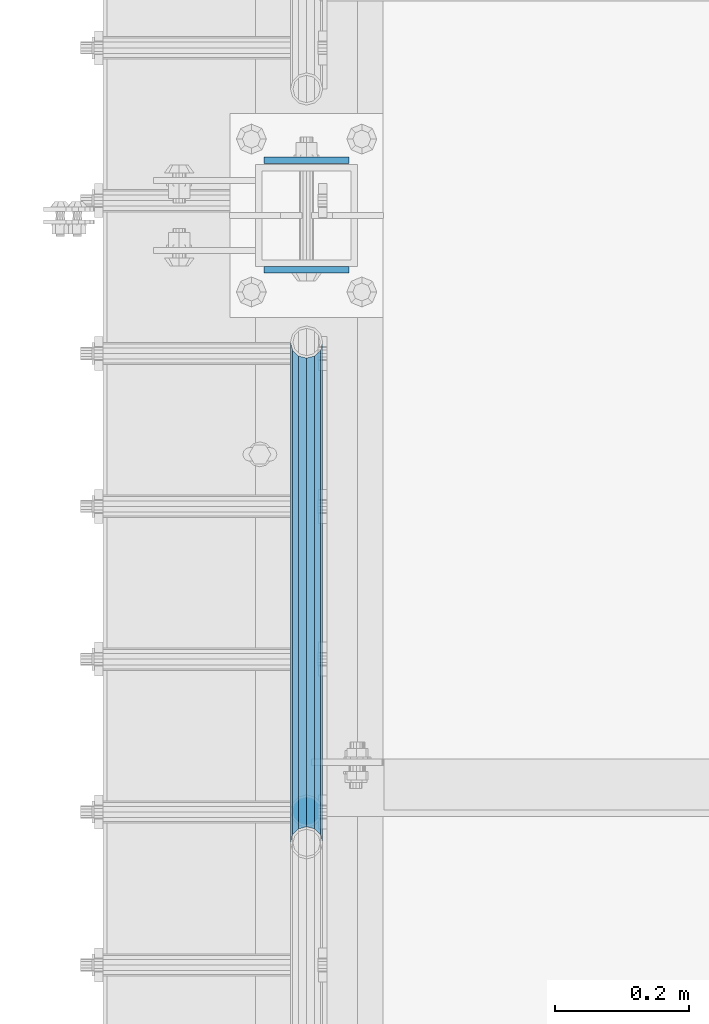
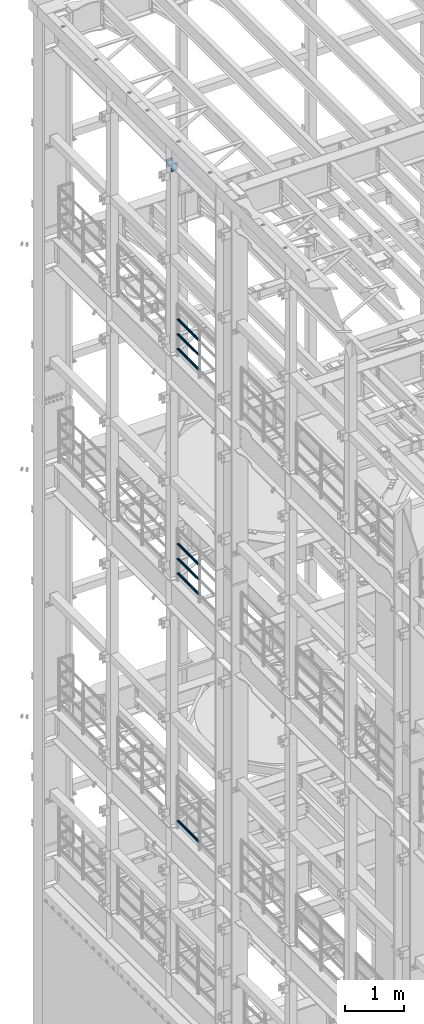
# One storey, part 1295 of 1876: 9 beams, 4 elements without a shape of their own.
"""IFC2X3 building model written with IfcOpenShell, lengths in millimetres."""

from ifc_helpers import new_model, si_unit, frame, origin_with_axes, place, context, subcontext, project, spatial, faceted_brep, material, type_object, element, aggregate, save


model = new_model("IFC2X3")

# Units and contexts
model_context = context("Model", 3, precision=1e-05, world=origin_with_axes())
body_context = subcontext(model_context, "Body", "Model", "MODEL_VIEW")
ifc_project = project(units=[si_unit("LENGTHUNIT", "METRE", prefix="MILLI"), si_unit("AREAUNIT", "SQUARE_METRE"), si_unit("VOLUMEUNIT", "CUBIC_METRE"), si_unit("MASSUNIT", "GRAM", prefix="KILO"), si_unit("TIMEUNIT", "SECOND"), si_unit("PLANEANGLEUNIT", "RADIAN"), si_unit("SOLIDANGLEUNIT", "STERADIAN"), si_unit("THERMODYNAMICTEMPERATUREUNIT", "DEGREE_CELSIUS"), si_unit("LUMINOUSINTENSITYUNIT", "LUMEN")], contexts=[model_context])

# Site, building, storey
site_placement = place(None, origin_with_axes())
site = spatial("IfcSite", under=ifc_project, at=site_placement, CompositionType="ELEMENT")
building_placement = place(site_placement, origin_with_axes())
building = spatial("IfcBuilding", under=site, at=building_placement, Name="Undefined", CompositionType="ELEMENT")
storey_placement = place(building_placement, origin_with_axes())
storey = spatial("IfcBuildingStorey", under=building, at=storey_placement, Name="Undefined", CompositionType="ELEMENT", Elevation=0.0)

# Assembly, beams
assembly_1_placement = place(storey_placement, origin_with_axes())
assembly_1 = element("IfcElementAssembly", 1, at=assembly_1_placement, inside=storey, Name="RAIL", AssemblyPlace="NOTDEFINED", PredefinedType="RIGID_FRAME")
ifc_material_1 = material()
beam_type_1 = type_object("IfcBeamType", Name="PIPE1-1/2SCH40", PredefinedType="NOTDEFINED")
beam_1_placement = place(assembly_1_placement, frame((-1.81898940354586e-12, 9462.77, 18145.125), z_axis=(0.0, 0.0, 1.0), x_axis=(0.0, -1.0, 0.0)))
beam_1 = element("IfcBeam", 2, at=beam_1_placement, type_object=beam_type_1, material=ifc_material_1, Name="RAIL", ObjectType="PIPE1-1/2SCH40", context=body_context, shape_type="Brep", body=[
    faceted_brep([(728.085307006683, -12.0649999999996, 20.8971929933177), (728.085307006683, -12.0649999999996, 15.8661214311796), (727.591878568821, -10.2235000000001, 17.7076214311819), (724.852500000002, 0.0, 20.4470000000001), (724.852500000002, 0.0, 24.130000000001), (727.591878568821, 10.2235000000001, 17.7076214311819), (728.085307006683, 12.0649999999996, 15.8661214311796), (728.085307006683, 12.0649999999996, 20.8971929933177), (748.982500000002, 24.1300000000001, 0.0), (736.917500000002, 20.8971929933186, 12.0649999999987), (736.917500000002, 20.8971929933186, -12.0649999999987), (733.727928437864, 17.7076214311801, 10.2235000000001), (736.467307006683, 20.4470000000001, 0.0), (733.727928437864, 17.7076214311801, -10.2235000000001), (728.085307006683, 12.0649999999996, -15.8661214311796), (728.085307006683, 12.0649999999996, -20.8971929933177), (727.591878568821, 10.2235000000001, -17.7076214311819), (724.852500000002, 0.0, -20.4470000000001), (724.852500000002, 0.0, -24.130000000001), (728.085307006683, -12.0649999999996, -15.8661214311796), (728.085307006683, -12.0649999999996, -20.8971929933177), (727.591878568821, -10.2235000000001, -17.7076214311819), (748.982500000002, -24.1300000000001, 0.0), (736.917500000002, -20.8971929933186, -12.0649999999987), (736.917500000002, -20.8971929933186, 12.0649999999987), (733.727928437864, -17.7076214311801, -10.2235000000001), (736.467307006683, -20.4470000000001, 0.0), (733.727928437864, -17.7076214311801, 10.2235000000001), (12.0650000000064, -20.8971929933177, -12.0649999999987), (20.8971929933249, -12.0650000000005, -20.8971929933177), (0.0, 24.1299999999992, 0.0), (12.0650000000064, 20.8971929933177, -12.0649999999987), (12.0650000000064, 20.8971929933177, 12.0649999999987), (20.8971929933249, 12.0650000000005, 20.8971929933177), (24.1300000000064, 0.0, 24.130000000001), (20.8971929933249, 12.0650000000005, -20.8971929933177), (24.1300000000063, 0.0, -24.130000000001), (24.1300000000063, 0.0, -20.4470000000001), (20.8971929933249, -12.0650000000005, -15.8661214311796), (21.3906214311868, -10.2235000000001, -17.7076214311819), (21.3906214311868, 10.2235000000001, -17.7076214311819), (20.8971929933249, 12.0650000000005, -15.8661214311796), (15.2545715621445, 17.7076214311801, -10.2235000000001), (12.5151929933249, 20.4470000000001, 0.0), (15.2545715621445, 17.7076214311801, 10.2235000000001), (20.8971929933249, 12.0650000000005, 15.8661214311796), (21.3906214311868, 10.2235000000001, 17.7076214311819), (24.1300000000064, 0.0, 20.4470000000001), (21.3906214311868, -10.2235000000001, 17.7076214311819), (20.8971929933249, -12.0650000000005, 15.8661214311796), (20.8971929933249, -12.0650000000005, 20.8971929933177), (12.0650000000064, -20.8971929933177, 12.0649999999987), (0.0, -24.1299999999992, 0.0), (15.2545715621445, -17.7076214311801, 10.2235000000001), (12.5151929933249, -20.4470000000001, 0.0), (15.2545715621445, -17.7076214311801, -10.2235000000001)], [[[0, 1, 2, 3, 4]], [[4, 3, 5, 6, 7]], [[8, 9, 10]], [[7, 6, 11, 12, 13, 14, 15, 10, 9]], [[16, 17, 18, 15, 14]], [[19, 20, 18, 17, 21]], [[22, 23, 24]], [[24, 23, 20, 19, 25, 26, 27, 1, 0]], [[28, 29, 20, 23]], [[30, 31, 32]], [[33, 34, 4, 7]], [[32, 33, 7, 9]], [[30, 32, 9, 8]], [[31, 30, 8, 10]], [[35, 31, 10, 15]], [[36, 35, 15, 18]], [[29, 36, 18, 20]], [[37, 36, 29, 38, 39]], [[40, 41, 35, 36, 37]], [[32, 31, 35, 41, 42, 43, 44, 45, 33]], [[33, 45, 46, 47, 34]], [[34, 47, 48, 49, 50]], [[34, 50, 0, 4]], [[50, 51, 24, 0]], [[51, 52, 22, 24]], [[52, 28, 23, 22]], [[51, 28, 52]], [[50, 49, 53, 54, 55, 38, 29, 28, 51]], [[55, 54, 26, 25]], [[21, 39, 38, 55, 25, 19]], [[37, 39, 21, 17]], [[40, 37, 17, 16]], [[42, 41, 40, 16, 14, 13]], [[43, 42, 13, 12]], [[44, 43, 12, 11]], [[5, 46, 45, 44, 11, 6]], [[47, 46, 5, 3]], [[48, 47, 3, 2]], [[53, 49, 48, 2, 1, 27]], [[54, 53, 27, 26]]]),
])
beam_2_placement = place(assembly_1_placement, frame((-1.81898940354586e-12, 8713.7875, 18449.925), z_axis=(0.0, 0.0, -1.0), x_axis=(0.0, 1.0, 0.0)))
beam_2 = element("IfcBeam", 3, at=beam_2_placement, type_object=beam_type_1, material=ifc_material_1, Name="RAIL", ObjectType="PIPE1-1/2SCH40", context=body_context, shape_type="Brep", body=[
    faceted_brep([(0.0, 24.1299999999992, 0.0), (12.0650000000064, 20.8971929933177, -12.0649999999987), (12.0650000000064, 20.8971929933177, 12.0649999999987), (12.0650000000064, -20.8971929933177, 12.0649999999987), (12.0650000000064, -20.8971929933177, -12.0649999999987), (0.0, -24.1299999999992, 0.0), (20.8971929933249, -12.0650000000005, 20.8971929933177), (20.8971929933249, -12.0650000000005, 15.8661214311796), (15.2545715621445, -17.7076214311801, 10.2235000000001), (12.5151929933249, -20.4470000000001, 0.0), (15.2545715621445, -17.7076214311801, -10.2235000000001), (20.8971929933249, -12.0650000000005, -15.8661214311796), (20.8971929933249, -12.0650000000005, -20.8971929933177), (24.1300000000063, 0.0, -20.4470000000001), (24.1300000000063, 0.0, -24.130000000001), (21.3906214311868, -10.2235000000001, -17.7076214311819), (21.3906214311868, 10.2235000000001, -17.7076214311819), (20.8971929933249, 12.0650000000005, -15.8661214311796), (20.8971929933249, 12.0650000000005, -20.8971929933177), (15.2545715621445, 17.7076214311801, -10.2235000000001), (12.5151929933249, 20.4470000000001, 0.0), (15.2545715621445, 17.7076214311801, 10.2235000000001), (20.8971929933249, 12.0650000000005, 15.8661214311796), (20.8971929933249, 12.0650000000005, 20.8971929933177), (21.3906214311868, 10.2235000000001, 17.7076214311819), (24.1300000000064, 0.0, 20.4470000000001), (24.1300000000064, 0.0, 24.130000000001), (21.3906214311868, -10.2235000000001, 17.7076214311819), (748.982500000002, 24.1300000000001, 0.0), (736.917500000002, 20.8971929933186, -12.0649999999987), (728.085307006683, 12.0649999999996, -20.8971929933177), (748.982500000002, -24.1300000000001, 0.0), (736.917500000002, -20.8971929933186, -12.0649999999987), (736.917500000002, -20.8971929933186, 12.0649999999987), (728.085307006683, -12.0649999999996, 20.8971929933177), (728.085307006683, -12.0649999999996, -20.8971929933177), (724.852500000002, 0.0, -24.130000000001), (727.591878568821, 10.2235000000001, -17.7076214311819), (724.852500000002, 0.0, -20.4470000000001), (728.085307006683, 12.0649999999996, -15.8661214311796), (728.085307006683, -12.0649999999996, -15.8661214311796), (727.591878568821, -10.2235000000001, -17.7076214311819), (733.727928437864, -17.7076214311801, -10.2235000000001), (736.467307006683, -20.4470000000001, 0.0), (733.727928437864, -17.7076214311801, 10.2235000000001), (728.085307006683, -12.0649999999996, 15.8661214311796), (727.591878568821, -10.2235000000001, 17.7076214311819), (724.852500000002, 0.0, 20.4470000000001), (724.852500000002, 0.0, 24.130000000001), (728.085307006683, 12.0649999999996, 20.8971929933177), (736.917500000002, 20.8971929933186, 12.0649999999987), (728.085307006683, 12.0649999999996, 15.8661214311796), (733.727928437864, 17.7076214311801, 10.2235000000001), (736.467307006683, 20.4470000000001, 0.0), (733.727928437864, 17.7076214311801, -10.2235000000001), (727.591878568821, 10.2235000000001, 17.7076214311819)], [[[0, 1, 2]], [[3, 4, 5]], [[6, 7, 8, 9, 10, 11, 12, 4, 3]], [[13, 14, 12, 11, 15]], [[16, 17, 18, 14, 13]], [[2, 1, 18, 17, 19, 20, 21, 22, 23]], [[23, 22, 24, 25, 26]], [[26, 25, 27, 7, 6]], [[1, 0, 28, 29]], [[18, 1, 29, 30]], [[31, 32, 33]], [[6, 3, 33, 34]], [[3, 5, 31, 33]], [[5, 4, 32, 31]], [[4, 12, 35, 32]], [[12, 14, 36, 35]], [[14, 18, 30, 36]], [[37, 38, 36, 30, 39]], [[40, 35, 36, 38, 41]], [[33, 32, 35, 40, 42, 43, 44, 45, 34]], [[34, 45, 46, 47, 48]], [[26, 6, 34, 48]], [[2, 23, 49, 50]], [[23, 26, 48, 49]], [[0, 2, 50, 28]], [[28, 50, 29]], [[49, 51, 52, 53, 54, 39, 30, 29, 50]], [[48, 47, 55, 51, 49]], [[25, 24, 55, 47]], [[55, 24, 22, 21, 52, 51]], [[21, 20, 53, 52]], [[20, 19, 54, 53]], [[19, 17, 16, 37, 39, 54]], [[16, 13, 38, 37]], [[13, 15, 41, 38]], [[41, 15, 11, 10, 42, 40]], [[10, 9, 43, 42]], [[9, 8, 44, 43]], [[8, 7, 27, 46, 45, 44]], [[27, 25, 47, 46]]]),
])
beam_3_placement = place(assembly_1_placement, frame((-1.81898940354586e-12, 8713.7875, 18754.725), z_axis=(0.0, 0.0, -1.0), x_axis=(0.0, 1.0, 0.0)))
beam_3 = element("IfcBeam", 4, at=beam_3_placement, type_object=beam_type_1, material=ifc_material_1, Name="RAIL", ObjectType="PIPE1-1/2SCH40", context=body_context, shape_type="Brep", body=[
    faceted_brep([(0.0, 24.1299999999992, 0.0), (12.0650000000064, 20.8971929933177, -12.0649999999987), (12.0650000000064, 20.8971929933177, 12.0649999999987), (12.0650000000064, -20.8971929933177, 12.0649999999987), (12.0650000000064, -20.8971929933177, -12.0649999999987), (0.0, -24.1299999999992, 0.0), (20.8971929933249, -12.0650000000005, 20.8971929933177), (20.8971929933249, -12.0650000000005, 15.8661214311796), (15.2545715621445, -17.7076214311801, 10.2235000000001), (12.5151929933249, -20.4470000000001, 0.0), (15.2545715621445, -17.7076214311801, -10.2235000000001), (20.8971929933249, -12.0650000000005, -15.8661214311796), (20.8971929933249, -12.0650000000005, -20.8971929933177), (24.1300000000063, 0.0, -20.4470000000001), (24.1300000000063, 0.0, -24.130000000001), (21.3906214311868, -10.2235000000001, -17.7076214311819), (21.3906214311868, 10.2235000000001, -17.7076214311819), (20.8971929933249, 12.0650000000005, -15.8661214311796), (20.8971929933249, 12.0650000000005, -20.8971929933177), (15.2545715621445, 17.7076214311801, -10.2235000000001), (12.5151929933249, 20.4470000000001, 0.0), (15.2545715621445, 17.7076214311801, 10.2235000000001), (20.8971929933249, 12.0650000000005, 15.8661214311796), (20.8971929933249, 12.0650000000005, 20.8971929933177), (21.3906214311868, 10.2235000000001, 17.7076214311819), (24.1300000000064, 0.0, 20.4470000000001), (24.1300000000064, 0.0, 24.130000000001), (21.3906214311868, -10.2235000000001, 17.7076214311819), (748.982500000002, 24.1300000000001, 0.0), (736.917500000002, 20.8971929933186, -12.0649999999987), (728.085307006683, 12.0649999999996, -20.8971929933177), (748.982500000002, -24.1300000000001, 0.0), (736.917500000002, -20.8971929933186, -12.0649999999987), (736.917500000002, -20.8971929933186, 12.0649999999987), (728.085307006683, -12.0649999999996, 20.8971929933177), (728.085307006683, -12.0649999999996, -20.8971929933177), (724.852500000002, 0.0, -24.130000000001), (727.591878568821, 10.2235000000001, -17.7076214311819), (724.852500000002, 0.0, -20.4470000000001), (728.085307006683, 12.0649999999996, -15.8661214311796), (728.085307006683, -12.0649999999996, -15.8661214311796), (727.591878568821, -10.2235000000001, -17.7076214311819), (733.727928437864, -17.7076214311801, -10.2235000000001), (736.467307006683, -20.4470000000001, 0.0), (733.727928437864, -17.7076214311801, 10.2235000000001), (728.085307006683, -12.0649999999996, 15.8661214311796), (727.591878568821, -10.2235000000001, 17.7076214311819), (724.852500000002, 0.0, 20.4470000000001), (724.852500000002, 0.0, 24.130000000001), (728.085307006683, 12.0649999999996, 20.8971929933177), (736.917500000002, 20.8971929933186, 12.0649999999987), (728.085307006683, 12.0649999999996, 15.8661214311796), (733.727928437864, 17.7076214311801, 10.2235000000001), (736.467307006683, 20.4470000000001, 0.0), (733.727928437864, 17.7076214311801, -10.2235000000001), (727.591878568821, 10.2235000000001, 17.7076214311819)], [[[0, 1, 2]], [[3, 4, 5]], [[6, 7, 8, 9, 10, 11, 12, 4, 3]], [[13, 14, 12, 11, 15]], [[16, 17, 18, 14, 13]], [[2, 1, 18, 17, 19, 20, 21, 22, 23]], [[23, 22, 24, 25, 26]], [[26, 25, 27, 7, 6]], [[1, 0, 28, 29]], [[18, 1, 29, 30]], [[31, 32, 33]], [[6, 3, 33, 34]], [[3, 5, 31, 33]], [[5, 4, 32, 31]], [[4, 12, 35, 32]], [[12, 14, 36, 35]], [[14, 18, 30, 36]], [[37, 38, 36, 30, 39]], [[40, 35, 36, 38, 41]], [[33, 32, 35, 40, 42, 43, 44, 45, 34]], [[34, 45, 46, 47, 48]], [[26, 6, 34, 48]], [[2, 23, 49, 50]], [[23, 26, 48, 49]], [[0, 2, 50, 28]], [[28, 50, 29]], [[49, 51, 52, 53, 54, 39, 30, 29, 50]], [[48, 47, 55, 51, 49]], [[25, 24, 55, 47]], [[55, 24, 22, 21, 52, 51]], [[21, 20, 53, 52]], [[20, 19, 54, 53]], [[19, 17, 16, 37, 39, 54]], [[16, 13, 38, 37]], [[13, 15, 41, 38]], [[41, 15, 11, 10, 42, 40]], [[10, 9, 43, 42]], [[9, 8, 44, 43]], [[8, 7, 27, 46, 45, 44]], [[27, 25, 47, 46]]]),
])
aggregate(assembly_1, [beam_1, beam_2, beam_3])

assembly_2_placement = place(storey_placement, origin_with_axes())
assembly_2 = element("IfcElementAssembly", 5, at=assembly_2_placement, inside=storey, Name="RAIL", AssemblyPlace="NOTDEFINED", PredefinedType="RIGID_FRAME")
beam_4_placement = place(assembly_2_placement, frame((-1.81898940354586e-12, 9462.77, 13471.525), z_axis=(0.0, 0.0, 1.0), x_axis=(0.0, -1.0, 0.0)))
beam_4 = element("IfcBeam", 6, at=beam_4_placement, type_object=beam_type_1, material=ifc_material_1, Name="RAIL", ObjectType="PIPE1-1/2SCH40", context=body_context, shape_type="Brep", body=[
    faceted_brep([(728.085307006683, -12.0649999999996, 20.8971929933177), (728.085307006683, -12.0649999999996, 15.8661214311796), (727.591878568821, -10.2235000000001, 17.7076214311819), (724.852500000002, 0.0, 20.4470000000001), (724.852500000002, 0.0, 24.130000000001), (727.591878568821, 10.2235000000001, 17.7076214311819), (728.085307006683, 12.0649999999996, 15.8661214311796), (728.085307006683, 12.0649999999996, 20.8971929933177), (748.982500000002, 24.1300000000001, 0.0), (736.917500000002, 20.8971929933186, 12.0649999999987), (736.917500000002, 20.8971929933186, -12.0649999999987), (733.727928437864, 17.7076214311801, 10.2235000000001), (736.467307006683, 20.4470000000001, 0.0), (733.727928437864, 17.7076214311801, -10.2235000000001), (728.085307006683, 12.0649999999996, -15.8661214311796), (728.085307006683, 12.0649999999996, -20.8971929933177), (727.591878568821, 10.2235000000001, -17.7076214311819), (724.852500000002, 0.0, -20.4470000000001), (724.852500000002, 0.0, -24.130000000001), (728.085307006683, -12.0649999999996, -15.8661214311796), (728.085307006683, -12.0649999999996, -20.8971929933177), (727.591878568821, -10.2235000000001, -17.7076214311819), (748.982500000002, -24.1300000000001, 0.0), (736.917500000002, -20.8971929933186, -12.0649999999987), (736.917500000002, -20.8971929933186, 12.0649999999987), (733.727928437864, -17.7076214311801, -10.2235000000001), (736.467307006683, -20.4470000000001, 0.0), (733.727928437864, -17.7076214311801, 10.2235000000001), (12.0650000000064, -20.8971929933177, -12.0649999999987), (20.8971929933249, -12.0650000000005, -20.8971929933177), (0.0, 24.1299999999992, 0.0), (12.0650000000064, 20.8971929933177, -12.0649999999987), (12.0650000000064, 20.8971929933177, 12.0649999999987), (20.8971929933249, 12.0650000000005, 20.8971929933177), (24.1300000000064, 0.0, 24.130000000001), (20.8971929933249, 12.0650000000005, -20.8971929933177), (24.1300000000063, 0.0, -24.130000000001), (24.1300000000063, 0.0, -20.4470000000001), (20.8971929933249, -12.0650000000005, -15.8661214311796), (21.3906214311868, -10.2235000000001, -17.7076214311819), (21.3906214311868, 10.2235000000001, -17.7076214311819), (20.8971929933249, 12.0650000000005, -15.8661214311796), (15.2545715621445, 17.7076214311801, -10.2235000000001), (12.5151929933249, 20.4470000000001, 0.0), (15.2545715621445, 17.7076214311801, 10.2235000000001), (20.8971929933249, 12.0650000000005, 15.8661214311796), (21.3906214311868, 10.2235000000001, 17.7076214311819), (24.1300000000064, 0.0, 20.4470000000001), (21.3906214311868, -10.2235000000001, 17.7076214311819), (20.8971929933249, -12.0650000000005, 15.8661214311796), (20.8971929933249, -12.0650000000005, 20.8971929933177), (12.0650000000064, -20.8971929933177, 12.0649999999987), (0.0, -24.1299999999992, 0.0), (15.2545715621445, -17.7076214311801, 10.2235000000001), (12.5151929933249, -20.4470000000001, 0.0), (15.2545715621445, -17.7076214311801, -10.2235000000001)], [[[0, 1, 2, 3, 4]], [[4, 3, 5, 6, 7]], [[8, 9, 10]], [[7, 6, 11, 12, 13, 14, 15, 10, 9]], [[16, 17, 18, 15, 14]], [[19, 20, 18, 17, 21]], [[22, 23, 24]], [[24, 23, 20, 19, 25, 26, 27, 1, 0]], [[28, 29, 20, 23]], [[30, 31, 32]], [[33, 34, 4, 7]], [[32, 33, 7, 9]], [[30, 32, 9, 8]], [[31, 30, 8, 10]], [[35, 31, 10, 15]], [[36, 35, 15, 18]], [[29, 36, 18, 20]], [[37, 36, 29, 38, 39]], [[40, 41, 35, 36, 37]], [[32, 31, 35, 41, 42, 43, 44, 45, 33]], [[33, 45, 46, 47, 34]], [[34, 47, 48, 49, 50]], [[34, 50, 0, 4]], [[50, 51, 24, 0]], [[51, 52, 22, 24]], [[52, 28, 23, 22]], [[51, 28, 52]], [[50, 49, 53, 54, 55, 38, 29, 28, 51]], [[55, 54, 26, 25]], [[21, 39, 38, 55, 25, 19]], [[37, 39, 21, 17]], [[40, 37, 17, 16]], [[42, 41, 40, 16, 14, 13]], [[43, 42, 13, 12]], [[44, 43, 12, 11]], [[5, 46, 45, 44, 11, 6]], [[47, 46, 5, 3]], [[48, 47, 3, 2]], [[53, 49, 48, 2, 1, 27]], [[54, 53, 27, 26]]]),
])
beam_5_placement = place(assembly_2_placement, frame((-1.81898940354586e-12, 8713.7875, 13776.325), z_axis=(0.0, 0.0, -1.0), x_axis=(0.0, 1.0, 0.0)))
beam_5 = element("IfcBeam", 7, at=beam_5_placement, type_object=beam_type_1, material=ifc_material_1, Name="RAIL", ObjectType="PIPE1-1/2SCH40", context=body_context, shape_type="Brep", body=[
    faceted_brep([(0.0, 24.1299999999992, 0.0), (12.0650000000064, 20.8971929933177, -12.0649999999987), (12.0650000000064, 20.8971929933177, 12.0649999999987), (12.0650000000064, -20.8971929933177, 12.0649999999987), (12.0650000000064, -20.8971929933177, -12.0649999999987), (0.0, -24.1299999999992, 0.0), (20.8971929933249, -12.0650000000005, 20.8971929933177), (20.8971929933249, -12.0650000000005, 15.8661214311796), (15.2545715621445, -17.7076214311801, 10.2235000000001), (12.5151929933249, -20.4470000000001, 0.0), (15.2545715621445, -17.7076214311801, -10.2235000000001), (20.8971929933249, -12.0650000000005, -15.8661214311796), (20.8971929933249, -12.0650000000005, -20.8971929933177), (24.1300000000063, 0.0, -20.4470000000001), (24.1300000000063, 0.0, -24.130000000001), (21.3906214311868, -10.2235000000001, -17.7076214311819), (21.3906214311868, 10.2235000000001, -17.7076214311819), (20.8971929933249, 12.0650000000005, -15.8661214311796), (20.8971929933249, 12.0650000000005, -20.8971929933177), (15.2545715621445, 17.7076214311801, -10.2235000000001), (12.5151929933249, 20.4470000000001, 0.0), (15.2545715621445, 17.7076214311801, 10.2235000000001), (20.8971929933249, 12.0650000000005, 15.8661214311796), (20.8971929933249, 12.0650000000005, 20.8971929933177), (21.3906214311868, 10.2235000000001, 17.7076214311819), (24.1300000000064, 0.0, 20.4470000000001), (24.1300000000064, 0.0, 24.130000000001), (21.3906214311868, -10.2235000000001, 17.7076214311819), (748.982500000002, 24.1300000000001, 0.0), (736.917500000002, 20.8971929933186, -12.0649999999987), (728.085307006683, 12.0649999999996, -20.8971929933177), (748.982500000002, -24.1300000000001, 0.0), (736.917500000002, -20.8971929933186, -12.0649999999987), (736.917500000002, -20.8971929933186, 12.0649999999987), (728.085307006683, -12.0649999999996, 20.8971929933177), (728.085307006683, -12.0649999999996, -20.8971929933177), (724.852500000002, 0.0, -24.130000000001), (727.591878568821, 10.2235000000001, -17.7076214311819), (724.852500000002, 0.0, -20.4470000000001), (728.085307006683, 12.0649999999996, -15.8661214311796), (728.085307006683, -12.0649999999996, -15.8661214311796), (727.591878568821, -10.2235000000001, -17.7076214311819), (733.727928437864, -17.7076214311801, -10.2235000000001), (736.467307006683, -20.4470000000001, 0.0), (733.727928437864, -17.7076214311801, 10.2235000000001), (728.085307006683, -12.0649999999996, 15.8661214311796), (727.591878568821, -10.2235000000001, 17.7076214311819), (724.852500000002, 0.0, 20.4470000000001), (724.852500000002, 0.0, 24.130000000001), (728.085307006683, 12.0649999999996, 20.8971929933177), (736.917500000002, 20.8971929933186, 12.0649999999987), (728.085307006683, 12.0649999999996, 15.8661214311796), (733.727928437864, 17.7076214311801, 10.2235000000001), (736.467307006683, 20.4470000000001, 0.0), (733.727928437864, 17.7076214311801, -10.2235000000001), (727.591878568821, 10.2235000000001, 17.7076214311819)], [[[0, 1, 2]], [[3, 4, 5]], [[6, 7, 8, 9, 10, 11, 12, 4, 3]], [[13, 14, 12, 11, 15]], [[16, 17, 18, 14, 13]], [[2, 1, 18, 17, 19, 20, 21, 22, 23]], [[23, 22, 24, 25, 26]], [[26, 25, 27, 7, 6]], [[1, 0, 28, 29]], [[18, 1, 29, 30]], [[31, 32, 33]], [[6, 3, 33, 34]], [[3, 5, 31, 33]], [[5, 4, 32, 31]], [[4, 12, 35, 32]], [[12, 14, 36, 35]], [[14, 18, 30, 36]], [[37, 38, 36, 30, 39]], [[40, 35, 36, 38, 41]], [[33, 32, 35, 40, 42, 43, 44, 45, 34]], [[34, 45, 46, 47, 48]], [[26, 6, 34, 48]], [[2, 23, 49, 50]], [[23, 26, 48, 49]], [[0, 2, 50, 28]], [[28, 50, 29]], [[49, 51, 52, 53, 54, 39, 30, 29, 50]], [[48, 47, 55, 51, 49]], [[25, 24, 55, 47]], [[55, 24, 22, 21, 52, 51]], [[21, 20, 53, 52]], [[20, 19, 54, 53]], [[19, 17, 16, 37, 39, 54]], [[16, 13, 38, 37]], [[13, 15, 41, 38]], [[41, 15, 11, 10, 42, 40]], [[10, 9, 43, 42]], [[9, 8, 44, 43]], [[8, 7, 27, 46, 45, 44]], [[27, 25, 47, 46]]]),
])
beam_6_placement = place(assembly_2_placement, frame((-1.81898940354586e-12, 8713.7875, 14081.125), z_axis=(0.0, 0.0, -1.0), x_axis=(0.0, 1.0, 0.0)))
beam_6 = element("IfcBeam", 8, at=beam_6_placement, type_object=beam_type_1, material=ifc_material_1, Name="RAIL", ObjectType="PIPE1-1/2SCH40", context=body_context, shape_type="Brep", body=[
    faceted_brep([(0.0, 24.1299999999992, 0.0), (12.0650000000064, 20.8971929933177, -12.0649999999987), (12.0650000000064, 20.8971929933177, 12.0649999999987), (12.0650000000064, -20.8971929933177, 12.0649999999987), (12.0650000000064, -20.8971929933177, -12.0649999999987), (0.0, -24.1299999999992, 0.0), (20.8971929933249, -12.0650000000005, 20.8971929933177), (20.8971929933249, -12.0650000000005, 15.8661214311796), (15.2545715621445, -17.7076214311801, 10.2235000000001), (12.5151929933249, -20.4470000000001, 0.0), (15.2545715621445, -17.7076214311801, -10.2235000000001), (20.8971929933249, -12.0650000000005, -15.8661214311796), (20.8971929933249, -12.0650000000005, -20.8971929933177), (24.1300000000063, 0.0, -20.4470000000001), (24.1300000000063, 0.0, -24.130000000001), (21.3906214311868, -10.2235000000001, -17.7076214311819), (21.3906214311868, 10.2235000000001, -17.7076214311819), (20.8971929933249, 12.0650000000005, -15.8661214311796), (20.8971929933249, 12.0650000000005, -20.8971929933177), (15.2545715621445, 17.7076214311801, -10.2235000000001), (12.5151929933249, 20.4470000000001, 0.0), (15.2545715621445, 17.7076214311801, 10.2235000000001), (20.8971929933249, 12.0650000000005, 15.8661214311796), (20.8971929933249, 12.0650000000005, 20.8971929933177), (21.3906214311868, 10.2235000000001, 17.7076214311819), (24.1300000000064, 0.0, 20.4470000000001), (24.1300000000064, 0.0, 24.130000000001), (21.3906214311868, -10.2235000000001, 17.7076214311819), (748.982500000002, 24.1300000000001, 0.0), (736.917500000002, 20.8971929933186, -12.0649999999987), (728.085307006683, 12.0649999999996, -20.8971929933177), (748.982500000002, -24.1300000000001, 0.0), (736.917500000002, -20.8971929933186, -12.0649999999987), (736.917500000002, -20.8971929933186, 12.0649999999987), (728.085307006683, -12.0649999999996, 20.8971929933177), (728.085307006683, -12.0649999999996, -20.8971929933177), (724.852500000002, 0.0, -24.130000000001), (727.591878568821, 10.2235000000001, -17.7076214311819), (724.852500000002, 0.0, -20.4470000000001), (728.085307006683, 12.0649999999996, -15.8661214311796), (728.085307006683, -12.0649999999996, -15.8661214311796), (727.591878568821, -10.2235000000001, -17.7076214311819), (733.727928437864, -17.7076214311801, -10.2235000000001), (736.467307006683, -20.4470000000001, 0.0), (733.727928437864, -17.7076214311801, 10.2235000000001), (728.085307006683, -12.0649999999996, 15.8661214311796), (727.591878568821, -10.2235000000001, 17.7076214311819), (724.852500000002, 0.0, 20.4470000000001), (724.852500000002, 0.0, 24.130000000001), (728.085307006683, 12.0649999999996, 20.8971929933177), (736.917500000002, 20.8971929933186, 12.0649999999987), (728.085307006683, 12.0649999999996, 15.8661214311796), (733.727928437864, 17.7076214311801, 10.2235000000001), (736.467307006683, 20.4470000000001, 0.0), (733.727928437864, 17.7076214311801, -10.2235000000001), (727.591878568821, 10.2235000000001, 17.7076214311819)], [[[0, 1, 2]], [[3, 4, 5]], [[6, 7, 8, 9, 10, 11, 12, 4, 3]], [[13, 14, 12, 11, 15]], [[16, 17, 18, 14, 13]], [[2, 1, 18, 17, 19, 20, 21, 22, 23]], [[23, 22, 24, 25, 26]], [[26, 25, 27, 7, 6]], [[1, 0, 28, 29]], [[18, 1, 29, 30]], [[31, 32, 33]], [[6, 3, 33, 34]], [[3, 5, 31, 33]], [[5, 4, 32, 31]], [[4, 12, 35, 32]], [[12, 14, 36, 35]], [[14, 18, 30, 36]], [[37, 38, 36, 30, 39]], [[40, 35, 36, 38, 41]], [[33, 32, 35, 40, 42, 43, 44, 45, 34]], [[34, 45, 46, 47, 48]], [[26, 6, 34, 48]], [[2, 23, 49, 50]], [[23, 26, 48, 49]], [[0, 2, 50, 28]], [[28, 50, 29]], [[49, 51, 52, 53, 54, 39, 30, 29, 50]], [[48, 47, 55, 51, 49]], [[25, 24, 55, 47]], [[55, 24, 22, 21, 52, 51]], [[21, 20, 53, 52]], [[20, 19, 54, 53]], [[19, 17, 16, 37, 39, 54]], [[16, 13, 38, 37]], [[13, 15, 41, 38]], [[41, 15, 11, 10, 42, 40]], [[10, 9, 43, 42]], [[9, 8, 44, 43]], [[8, 7, 27, 46, 45, 44]], [[27, 25, 47, 46]]]),
])
aggregate(assembly_2, [beam_4, beam_5, beam_6])

# Assembly, beam
assembly_3_placement = place(storey_placement, origin_with_axes())
assembly_3 = element("IfcElementAssembly", 9, at=assembly_3_placement, inside=storey, Name="RAIL", AssemblyPlace="NOTDEFINED", PredefinedType="RIGID_FRAME")
beam_7_placement = place(assembly_3_placement, frame((-1.81898940354586e-12, 9462.77, 8315.325), z_axis=(0.0, 0.0, 1.0), x_axis=(0.0, -1.0, 0.0)))
beam_7 = element("IfcBeam", 10, at=beam_7_placement, type_object=beam_type_1, material=ifc_material_1, Name="RAIL", ObjectType="PIPE1-1/2SCH40", context=body_context, shape_type="Brep", body=[
    faceted_brep([(728.085307006683, -12.0649999999996, 20.8971929933177), (728.085307006683, -12.0649999999996, 15.8661214311796), (727.591878568821, -10.2235000000001, 17.7076214311819), (724.852500000002, 0.0, 20.4470000000001), (724.852500000002, 0.0, 24.130000000001), (727.591878568821, 10.2235000000001, 17.7076214311819), (728.085307006683, 12.0649999999996, 15.8661214311796), (728.085307006683, 12.0649999999996, 20.8971929933177), (748.982500000002, 24.1300000000001, 0.0), (736.917500000002, 20.8971929933186, 12.0649999999987), (736.917500000002, 20.8971929933186, -12.0649999999987), (733.727928437864, 17.7076214311801, 10.2235000000001), (736.467307006683, 20.4470000000001, 0.0), (733.727928437864, 17.7076214311801, -10.2235000000001), (728.085307006683, 12.0649999999996, -15.8661214311796), (728.085307006683, 12.0649999999996, -20.8971929933177), (727.591878568821, 10.2235000000001, -17.7076214311819), (724.852500000002, 0.0, -20.4470000000001), (724.852500000002, 0.0, -24.130000000001), (728.085307006683, -12.0649999999996, -15.8661214311796), (728.085307006683, -12.0649999999996, -20.8971929933177), (727.591878568821, -10.2235000000001, -17.7076214311819), (748.982500000002, -24.1300000000001, 0.0), (736.917500000002, -20.8971929933186, -12.0649999999987), (736.917500000002, -20.8971929933186, 12.0649999999987), (733.727928437864, -17.7076214311801, -10.2235000000001), (736.467307006683, -20.4470000000001, 0.0), (733.727928437864, -17.7076214311801, 10.2235000000001), (12.0650000000064, -20.8971929933177, -12.0649999999987), (20.8971929933249, -12.0650000000005, -20.8971929933177), (0.0, 24.1299999999992, 0.0), (12.0650000000064, 20.8971929933177, -12.0649999999987), (12.0650000000064, 20.8971929933177, 12.0649999999987), (20.8971929933249, 12.0650000000005, 20.8971929933177), (24.1300000000064, 0.0, 24.130000000001), (20.8971929933249, 12.0650000000005, -20.8971929933177), (24.1300000000063, 0.0, -24.130000000001), (24.1300000000063, 0.0, -20.4470000000001), (20.8971929933249, -12.0650000000005, -15.8661214311796), (21.3906214311868, -10.2235000000001, -17.7076214311819), (21.3906214311868, 10.2235000000001, -17.7076214311819), (20.8971929933249, 12.0650000000005, -15.8661214311796), (15.2545715621445, 17.7076214311801, -10.2235000000001), (12.5151929933249, 20.4470000000001, 0.0), (15.2545715621445, 17.7076214311801, 10.2235000000001), (20.8971929933249, 12.0650000000005, 15.8661214311796), (21.3906214311868, 10.2235000000001, 17.7076214311819), (24.1300000000064, 0.0, 20.4470000000001), (21.3906214311868, -10.2235000000001, 17.7076214311819), (20.8971929933249, -12.0650000000005, 15.8661214311796), (20.8971929933249, -12.0650000000005, 20.8971929933177), (12.0650000000064, -20.8971929933177, 12.0649999999987), (0.0, -24.1299999999992, 0.0), (15.2545715621445, -17.7076214311801, 10.2235000000001), (12.5151929933249, -20.4470000000001, 0.0), (15.2545715621445, -17.7076214311801, -10.2235000000001)], [[[0, 1, 2, 3, 4]], [[4, 3, 5, 6, 7]], [[8, 9, 10]], [[7, 6, 11, 12, 13, 14, 15, 10, 9]], [[16, 17, 18, 15, 14]], [[19, 20, 18, 17, 21]], [[22, 23, 24]], [[24, 23, 20, 19, 25, 26, 27, 1, 0]], [[28, 29, 20, 23]], [[30, 31, 32]], [[33, 34, 4, 7]], [[32, 33, 7, 9]], [[30, 32, 9, 8]], [[31, 30, 8, 10]], [[35, 31, 10, 15]], [[36, 35, 15, 18]], [[29, 36, 18, 20]], [[37, 36, 29, 38, 39]], [[40, 41, 35, 36, 37]], [[32, 31, 35, 41, 42, 43, 44, 45, 33]], [[33, 45, 46, 47, 34]], [[34, 47, 48, 49, 50]], [[34, 50, 0, 4]], [[50, 51, 24, 0]], [[51, 52, 22, 24]], [[52, 28, 23, 22]], [[51, 28, 52]], [[50, 49, 53, 54, 55, 38, 29, 28, 51]], [[55, 54, 26, 25]], [[21, 39, 38, 55, 25, 19]], [[37, 39, 21, 17]], [[40, 37, 17, 16]], [[42, 41, 40, 16, 14, 13]], [[43, 42, 13, 12]], [[44, 43, 12, 11]], [[5, 46, 45, 44, 11, 6]], [[47, 46, 5, 3]], [[48, 47, 3, 2]], [[53, 49, 48, 2, 1, 27]], [[54, 53, 27, 26]]]),
])
aggregate(assembly_3, [beam_7])

# Assembly, beams
assembly_4_placement = place(storey_placement, origin_with_axes())
assembly_4 = element("IfcElementAssembly", 11, at=assembly_4_placement, inside=storey, Name="BEAM", AssemblyPlace="NOTDEFINED", PredefinedType="RIGID_FRAME")
ifc_material_2 = material(Name="STEEL/A36")
beam_type_2 = type_object("IfcBeamType", PredefinedType="NOTDEFINED")
beam_8_placement = place(assembly_4_placement, frame((-63.5, 9734.55, 21850.35), z_axis=(0.0, 0.0, -1.0), x_axis=(1.0, 0.0, 0.0)))
beam_8 = element("IfcBeam", 12, at=beam_8_placement, type_object=beam_type_2, material=ifc_material_2, Name="PLATE", context=body_context, shape_type="Brep", body=[
    faceted_brep([(0.0, 4.76249999999982, -82.5499999999993), (0.0, 4.76249999999982, 82.5499999999993), (127.0, 4.76249999999982, 82.5499999999993), (127.0, 4.76249999999982, -82.5499999999993), (0.0, -4.76249999999982, 82.5499999999993), (127.0, -4.76249999999982, 82.5499999999993), (0.0, -4.76249999999982, -82.5499999999993), (127.0, -4.76249999999982, -82.5499999999993)], [[[0, 1, 2, 3]], [[1, 4, 5, 2]], [[4, 6, 7, 5]], [[6, 0, 3, 7]], [[5, 7, 3, 2]], [[6, 4, 1, 0]]]),
])
beam_9_placement = place(assembly_4_placement, frame((-63.5, 9571.0375, 21850.35), z_axis=(0.0, 0.0, -1.0), x_axis=(1.0, 0.0, 0.0)))
beam_9 = element("IfcBeam", 13, at=beam_9_placement, type_object=beam_type_2, material=ifc_material_2, Name="PLATE", context=body_context, shape_type="Brep", body=[
    faceted_brep([(0.0, 4.76249999999982, -82.5499999999993), (0.0, 4.76249999999982, 82.5499999999993), (127.0, 4.76249999999982, 82.5499999999993), (127.0, 4.76249999999982, -82.5499999999993), (0.0, -4.76249999999982, 82.5499999999993), (127.0, -4.76249999999982, 82.5499999999993), (0.0, -4.76249999999982, -82.5499999999993), (127.0, -4.76249999999982, -82.5499999999993)], [[[0, 1, 2, 3]], [[1, 4, 5, 2]], [[4, 6, 7, 5]], [[6, 0, 3, 7]], [[5, 7, 3, 2]], [[6, 4, 1, 0]]]),
])
aggregate(assembly_4, [beam_8, beam_9])

save(model, "model.ifc")
